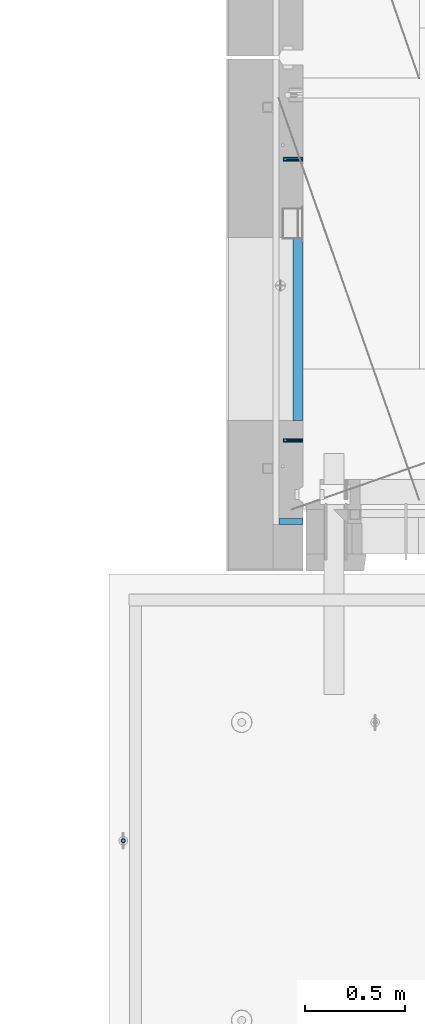
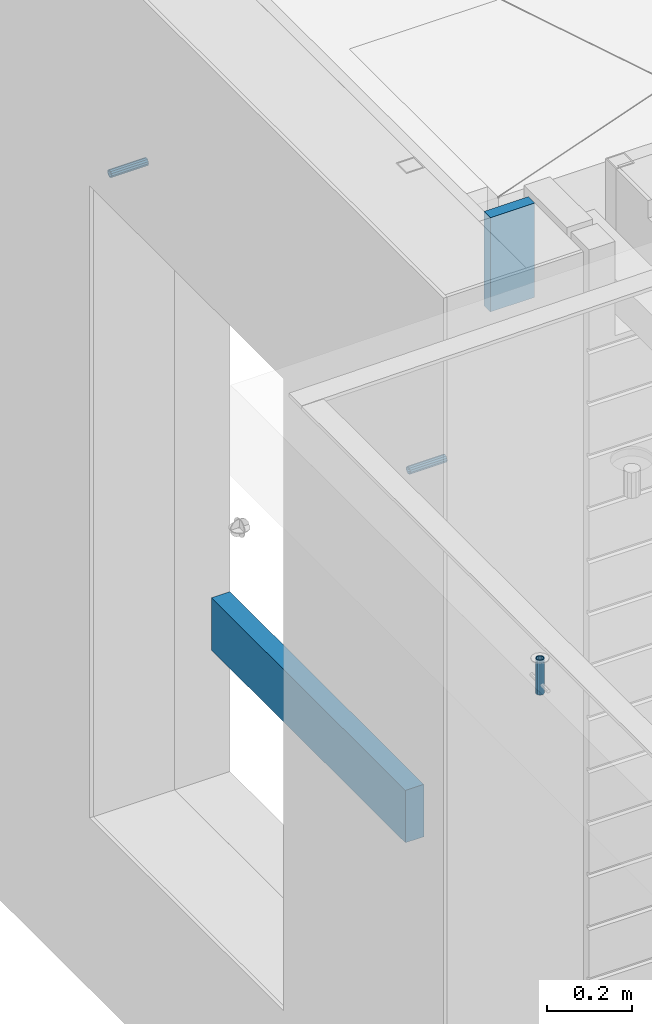
# One storey, part 133 of 341: 5 beams, 5 elements without a shape of their own.
"""IFC2X3 building model written with IfcOpenShell, lengths in millimetres."""

from ifc_helpers import new_model, si_unit, frame, origin_with_axes, place, context, subcontext, project, spatial, faceted_brep, material, type_object, element, aggregate, save


model = new_model("IFC2X3")

# Units and contexts
model_context = context("Model", 3, precision=1e-05, world=origin_with_axes())
body_context = subcontext(model_context, "Body", "Model", "MODEL_VIEW")
ifc_project = project(units=[si_unit("LENGTHUNIT", "METRE", prefix="MILLI"), si_unit("AREAUNIT", "SQUARE_METRE"), si_unit("VOLUMEUNIT", "CUBIC_METRE"), si_unit("MASSUNIT", "GRAM", prefix="KILO"), si_unit("TIMEUNIT", "SECOND"), si_unit("PLANEANGLEUNIT", "RADIAN"), si_unit("SOLIDANGLEUNIT", "STERADIAN"), si_unit("THERMODYNAMICTEMPERATUREUNIT", "DEGREE_CELSIUS"), si_unit("LUMINOUSINTENSITYUNIT", "LUMEN")], contexts=[model_context])

# Site, building, storey
site_placement = place(None, origin_with_axes())
site = spatial("IfcSite", under=ifc_project, at=site_placement, CompositionType="ELEMENT")
building_placement = place(site_placement, origin_with_axes())
building = spatial("IfcBuilding", under=site, at=building_placement, CompositionType="ELEMENT")
storey_placement = place(building_placement, origin_with_axes())
storey = spatial("IfcBuildingStorey", under=building, at=storey_placement, Name="5", CompositionType="ELEMENT", Elevation=0.0)

# Assemblies, beams
assembly_1_placement = place(storey_placement, origin_with_axes())
assembly_1 = element("IfcElementAssembly", 1, at=assembly_1_placement, inside=storey, AssemblyPlace="NOTDEFINED", PredefinedType="REINFORCEMENT_UNIT")
assembly_2_placement = place(assembly_1_placement, origin_with_axes())
assembly_2 = element("IfcElementAssembly", 2, at=assembly_2_placement, Name="Steel Assembly", AssemblyPlace="NOTDEFINED", PredefinedType="RIGID_FRAME")
ifc_material_1 = material(Name="STEEL/Steel_Undefined")
beam_type_1 = type_object("IfcBeamType", PredefinedType="NOTDEFINED")
beam_1_placement = place(assembly_2_placement, frame((7999.99979286169, 12695.8445842197, 95755.0), z_axis=(0.0, 1.0, 0.0), x_axis=(-1.0, 3.00000001838171e-08, 0.0)))
beam_1 = element("IfcBeam", 3, at=beam_1_placement, type_object=beam_type_1, material=ifc_material_1, Name="M16", context=body_context, shape_type="Brep", body=[
    faceted_brep([(0.0, -8.49999999999272, -1.45519152283669e-11), (0.0, -7.36121593215648, 4.24999999998545), (100.000000000262, -7.36121593215648, 4.24999999998545), (100.000000000262, -8.49999999999272, -1.45519152283669e-11), (0.0, -4.24999999998545, 7.36121593216376), (100.000000000262, -4.24999999998545, 7.36121593216376), (0.0, 1.45519152283669e-11, 8.49999999998545), (100.000000000262, 1.45519152283669e-11, 8.49999999998545), (0.0, 4.25000000001455, 7.36121593216376), (100.000000000262, 4.25000000001455, 7.36121593216376), (0.0, 7.36121593217104, 4.24999999998545), (100.000000000262, 7.36121593217104, 4.24999999998545), (0.0, 8.50000000000728, 0.0), (100.000000000262, 8.50000000000728, 0.0), (0.0, 7.36121593217104, -4.25000000001455), (100.000000000262, 7.36121593217104, -4.25000000001455), (0.0, 4.25000000000728, -7.36121593219286), (100.000000000262, 4.25000000000728, -7.36121593219286), (0.0, 7.27595761418343e-12, -8.5), (100.000000000262, 7.27595761418343e-12, -8.5), (0.0, -4.24999999999272, -7.36121593217831), (100.000000000262, -4.24999999999272, -7.36121593217831), (0.0, -7.36121593215648, -4.25), (100.000000000262, -7.36121593215648, -4.25), (0.0, -10.4999999999927, -1.45519152283669e-11), (0.0, -9.09326673972828, -5.25000000001455), (100.000000000262, -9.09326673972828, -5.25000000001455), (100.000000000262, -10.4999999999927, -1.45519152283669e-11), (0.0, -5.24999999998545, -9.09326673974283), (100.000000000262, -5.24999999998545, -9.09326673974283), (0.0, 7.27595761418343e-12, -10.5), (100.000000000262, 7.27595761418343e-12, -10.5), (0.0, 5.25000000001455, -9.09326673975738), (100.000000000262, 5.25000000001455, -9.09326673975738), (0.0, 9.09326673975011, -5.25000000001455), (100.000000000262, 9.09326673975011, -5.25000000001455), (0.0, 10.5000000000073, -1.45519152283669e-11), (100.000000000262, 10.5000000000073, -1.45519152283669e-11), (0.0, 9.09326673975011, 5.25), (100.000000000262, 9.09326673975011, 5.25), (0.0, 5.25000000000728, 9.09326673972828), (100.000000000262, 5.25000000000728, 9.09326673972828), (0.0, 1.45519152283669e-11, 10.4999999999854), (100.000000000262, 1.45519152283669e-11, 10.4999999999854), (0.0, -5.24999999999272, 9.09326673972828), (100.000000000262, -5.24999999999272, 9.09326673972828), (0.0, -9.09326673972828, 5.24999999998545), (100.000000000262, -9.09326673972828, 5.24999999998545)], [[[0, 1, 2, 3]], [[1, 4, 5, 2]], [[4, 6, 7, 5]], [[6, 8, 9, 7]], [[8, 10, 11, 9]], [[10, 12, 13, 11]], [[12, 14, 15, 13]], [[14, 16, 17, 15]], [[16, 18, 19, 17]], [[18, 20, 21, 19]], [[20, 22, 23, 21]], [[22, 0, 3, 23]], [[24, 25, 26, 27]], [[25, 28, 29, 26]], [[28, 30, 31, 29]], [[30, 32, 33, 31]], [[32, 34, 35, 33]], [[34, 36, 37, 35]], [[36, 38, 39, 37]], [[38, 40, 41, 39]], [[40, 42, 43, 41]], [[42, 44, 45, 43]], [[44, 46, 47, 45]], [[46, 24, 27, 47]], [[29, 31, 33, 35, 37, 39, 41, 43, 45, 47, 27, 26], [5, 7, 9, 11, 13, 15, 17, 19, 21, 23, 3, 2]], [[46, 44, 42, 40, 38, 36, 34, 32, 30, 28, 25, 24], [22, 20, 18, 16, 14, 12, 10, 8, 6, 4, 1, 0]]]),
])
aggregate(assembly_2, [beam_1])
assembly_3_placement = place(assembly_1_placement, origin_with_axes())
assembly_3 = element("IfcElementAssembly", 4, at=assembly_3_placement, Name="Steel Assembly", AssemblyPlace="NOTDEFINED", PredefinedType="RIGID_FRAME")
beam_2_placement = place(assembly_3_placement, frame((7999.99997194106, 11295.0002221546, 95755.0), z_axis=(0.0, -1.0, 0.0), x_axis=(-1.0, 3.00000001838171e-08, 0.0)))
beam_2 = element("IfcBeam", 5, at=beam_2_placement, type_object=beam_type_1, material=ifc_material_1, Name="M16", context=body_context, shape_type="Brep", body=[
    faceted_brep([(0.0, -8.49999999999272, -1.45519152283669e-11), (0.0, -7.36121593215648, 4.24999999998545), (100.000000000262, -7.36121593215648, 4.24999999998545), (100.000000000262, -8.49999999999272, -1.45519152283669e-11), (0.0, -4.24999999998545, 7.36121593216376), (100.000000000262, -4.24999999998545, 7.36121593216376), (0.0, 1.45519152283669e-11, 8.49999999998545), (100.000000000262, 1.45519152283669e-11, 8.49999999998545), (0.0, 4.25000000001455, 7.36121593216376), (100.000000000262, 4.25000000001455, 7.36121593216376), (0.0, 7.36121593217104, 4.24999999998545), (100.000000000262, 7.36121593217104, 4.24999999998545), (0.0, 8.50000000000728, 0.0), (100.000000000262, 8.50000000000728, 0.0), (0.0, 7.36121593217104, -4.25000000001455), (100.000000000262, 7.36121593217104, -4.25000000001455), (0.0, 4.25000000000728, -7.36121593219286), (100.000000000262, 4.25000000000728, -7.36121593219286), (0.0, 7.27595761418343e-12, -8.5), (100.000000000262, 7.27595761418343e-12, -8.5), (0.0, -4.24999999999272, -7.36121593217831), (100.000000000262, -4.24999999999272, -7.36121593217831), (0.0, -7.36121593215648, -4.25), (100.000000000262, -7.36121593215648, -4.25), (0.0, -10.4999999999927, -1.45519152283669e-11), (0.0, -9.09326673972828, -5.25000000001455), (100.000000000262, -9.09326673972828, -5.25000000001455), (100.000000000262, -10.4999999999927, -1.45519152283669e-11), (0.0, -5.24999999998545, -9.09326673974283), (100.000000000262, -5.24999999998545, -9.09326673974283), (0.0, 7.27595761418343e-12, -10.5), (100.000000000262, 7.27595761418343e-12, -10.5), (0.0, 5.25000000001455, -9.09326673975738), (100.000000000262, 5.25000000001455, -9.09326673975738), (0.0, 9.09326673975011, -5.25000000001455), (100.000000000262, 9.09326673975011, -5.25000000001455), (0.0, 10.5000000000073, -1.45519152283669e-11), (100.000000000262, 10.5000000000073, -1.45519152283669e-11), (0.0, 9.09326673975011, 5.25), (100.000000000262, 9.09326673975011, 5.25), (0.0, 5.25000000000728, 9.09326673972828), (100.000000000262, 5.25000000000728, 9.09326673972828), (0.0, 1.45519152283669e-11, 10.4999999999854), (100.000000000262, 1.45519152283669e-11, 10.4999999999854), (0.0, -5.24999999999272, 9.09326673972828), (100.000000000262, -5.24999999999272, 9.09326673972828), (0.0, -9.09326673972828, 5.24999999998545), (100.000000000262, -9.09326673972828, 5.24999999998545)], [[[0, 1, 2, 3]], [[1, 4, 5, 2]], [[4, 6, 7, 5]], [[6, 8, 9, 7]], [[8, 10, 11, 9]], [[10, 12, 13, 11]], [[12, 14, 15, 13]], [[14, 16, 17, 15]], [[16, 18, 19, 17]], [[18, 20, 21, 19]], [[20, 22, 23, 21]], [[22, 0, 3, 23]], [[24, 25, 26, 27]], [[25, 28, 29, 26]], [[28, 30, 31, 29]], [[30, 32, 33, 31]], [[32, 34, 35, 33]], [[34, 36, 37, 35]], [[36, 38, 39, 37]], [[38, 40, 41, 39]], [[40, 42, 43, 41]], [[42, 44, 45, 43]], [[44, 46, 47, 45]], [[46, 24, 27, 47]], [[29, 31, 33, 35, 37, 39, 41, 43, 45, 47, 27, 26], [5, 7, 9, 11, 13, 15, 17, 19, 21, 23, 3, 2]], [[46, 44, 42, 40, 38, 36, 34, 32, 30, 28, 25, 24], [22, 20, 18, 16, 14, 12, 10, 8, 6, 4, 1, 0]]]),
])
aggregate(assembly_3, [beam_2])

# Assemblies, beam
assembly_4_placement = place(storey_placement, origin_with_axes())
assembly_4 = element("IfcElementAssembly", 6, at=assembly_4_placement, inside=storey, AssemblyPlace="NOTDEFINED", PredefinedType="REINFORCEMENT_UNIT")
assembly_5_placement = place(assembly_4_placement, origin_with_axes())
assembly_5 = element("IfcElementAssembly", 7, at=assembly_5_placement, Name="Steel Assembly", AssemblyPlace="NOTDEFINED", PredefinedType="RIGID_FRAME")
aggregate(assembly_4, [assembly_5])
ifc_material_2 = material(Name="STEEL/1.4301")
beam_type_2 = type_object("IfcBeamType", PredefinedType="NOTDEFINED")
beam_3_placement = place(assembly_5_placement, frame((7104.95302979293, 9299.99671368706, 96706.0000000179), z_axis=(0.999999999993412, 3.63000011325366e-06, 0.0), x_axis=(0.0, -4.36599999292741e-06, -0.999999999990469)))
beam_3 = element("IfcBeam", 8, at=beam_3_placement, type_object=beam_type_2, material=ifc_material_2, context=body_context, shape_type="Brep", body=[
    faceted_brep([(0.0, -8.0, 0.0), (0.0, -6.92820323027263, 4.0), (100.000000000029, -6.92820323027263, 4.0), (100.000000000029, -7.99999999999636, 0.0), (0.0, -4.0, 6.92820323027627), (100.000000000029, -4.0, 6.92820323027536), (0.0, 0.0, 8.0), (100.000000000029, 3.63797880709171e-12, 8.0), (0.0, 4.0, 6.92820323027627), (100.000000000029, 4.0, 6.92820323027536), (0.0, 6.92820323027263, 4.0), (100.000000000029, 6.92820323027627, 3.99999999999909), (0.0, 8.0, 0.0), (100.000000000029, 8.0, 0.0), (0.0, 6.92820323027263, -4.0), (100.000000000029, 6.92820323027627, -4.00000000000091), (0.0, 4.0, -6.92820323027627), (100.000000000029, 4.00000000000364, -6.92820323027536), (0.0, 0.0, -8.0), (100.000000000029, 3.63797880709171e-12, -8.00000000000091), (0.0, -4.0, -6.92820323027627), (100.000000000029, -3.99999999999636, -6.92820323027627), (0.0, -6.92820323027263, -4.0), (100.000000000029, -6.92820323027263, -4.0), (0.0, -10.4999999999927, -1.45519152283669e-11), (0.0, -9.09326673972828, -5.25000000001455), (100.000000000262, -9.09326673972828, -5.25000000001455), (100.000000000262, -10.4999999999927, -1.45519152283669e-11), (0.0, -5.24999999998545, -9.09326673974283), (100.000000000262, -5.24999999998545, -9.09326673974283), (0.0, 7.27595761418343e-12, -10.5), (100.000000000262, 7.27595761418343e-12, -10.5), (0.0, 5.25000000001455, -9.09326673975738), (100.000000000262, 5.25000000001455, -9.09326673975738), (0.0, 9.09326673975011, -5.25000000001455), (100.000000000262, 9.09326673975011, -5.25000000001455), (0.0, 10.5000000000073, -1.45519152283669e-11), (100.000000000262, 10.5000000000073, -1.45519152283669e-11), (0.0, 9.09326673975011, 5.25), (100.000000000262, 9.09326673975011, 5.25), (0.0, 5.25000000000728, 9.09326673972828), (100.000000000262, 5.25000000000728, 9.09326673972828), (0.0, 1.45519152283669e-11, 10.4999999999854), (100.000000000262, 1.45519152283669e-11, 10.4999999999854), (0.0, -5.24999999999272, 9.09326673972828), (100.000000000262, -5.24999999999272, 9.09326673972828), (0.0, -9.09326673972828, 5.24999999998545), (100.000000000262, -9.09326673972828, 5.24999999998545)], [[[0, 1, 2, 3]], [[1, 4, 5, 2]], [[4, 6, 7, 5]], [[6, 8, 9, 7]], [[8, 10, 11, 9]], [[10, 12, 13, 11]], [[12, 14, 15, 13]], [[14, 16, 17, 15]], [[16, 18, 19, 17]], [[18, 20, 21, 19]], [[20, 22, 23, 21]], [[22, 0, 3, 23]], [[24, 25, 26, 27]], [[25, 28, 29, 26]], [[28, 30, 31, 29]], [[30, 32, 33, 31]], [[32, 34, 35, 33]], [[34, 36, 37, 35]], [[36, 38, 39, 37]], [[38, 40, 41, 39]], [[40, 42, 43, 41]], [[42, 44, 45, 43]], [[44, 46, 47, 45]], [[46, 24, 27, 47]], [[29, 31, 33, 35, 37, 39, 41, 43, 45, 47, 27, 26], [5, 7, 9, 11, 13, 15, 17, 19, 21, 23, 3, 2]], [[46, 44, 42, 40, 38, 36, 34, 32, 30, 28, 25, 24], [22, 20, 18, 16, 14, 12, 10, 8, 6, 4, 1, 0]]]),
])
aggregate(assembly_5, [beam_3])

# Beam
ifc_material_3 = material(Name="TIMBER/T24")
beam_type_3 = type_object("IfcBeamType", PredefinedType="NOTDEFINED")
beam_4_placement = place(assembly_1_placement, frame((7975.00000026382, 12305.0002963341, 94685.0), z_axis=(0.0, 0.0, 1.0), x_axis=(0.0, -1.0, 0.0)))
beam_4 = element("IfcBeam", 9, at=beam_4_placement, type_object=beam_type_3, material=ifc_material_3, context=body_context, shape_type="Brep", body=[
    faceted_brep([(-3.63797880709171e-12, 24.9999999999964, -75.0), (-3.63797880709171e-12, 24.9999999999964, 75.0), (909.999999999993, 25.0, 75.0), (909.999999999993, 25.0, -75.0), (0.0, -25.0000000000073, 75.0), (909.999999999993, -25.0, 75.0), (0.0, -25.0000000000073, -75.0), (909.999999999993, -25.0, -75.0)], [[[0, 1, 2, 3]], [[1, 4, 5, 2]], [[4, 6, 7, 5]], [[6, 0, 3, 7]], [[5, 7, 3, 2]], [[6, 4, 1, 0]]]),
])

ifc_material_4 = material(Name="CONCRETE/C25/30")
beam_type_4 = type_object("IfcBeamType", Name="270X30", PredefinedType="NOTDEFINED")
beam_5_placement = place(assembly_1_placement, frame((7880.00002749681, 10889.9997019753, 96604.9999999983), z_axis=(0.0, 0.0, 1.0), x_axis=(1.0, 0.0, 0.0)))
beam_5 = element("IfcBeam", 10, at=beam_5_placement, type_object=beam_type_4, material=ifc_material_4, ObjectType="270X30", context=body_context, shape_type="Brep", body=[
    faceted_brep([(0.0, 15.0, -135.0), (0.0, 15.0, 135.0), (119.999999999978, 15.0, 135.0), (119.999999999978, 15.0, -135.0), (0.0, -15.0, 135.0), (119.999999999978, -15.0, 135.0), (0.0, -15.0, -135.0), (119.999999999978, -15.0, -135.0)], [[[0, 1, 2, 3]], [[1, 4, 5, 2]], [[4, 6, 7, 5]], [[6, 0, 3, 7]], [[5, 7, 3, 2]], [[6, 4, 1, 0]]]),
])

aggregate(assembly_1, [assembly_2, assembly_3, beam_5, beam_4])

save(model, "model.ifc")
